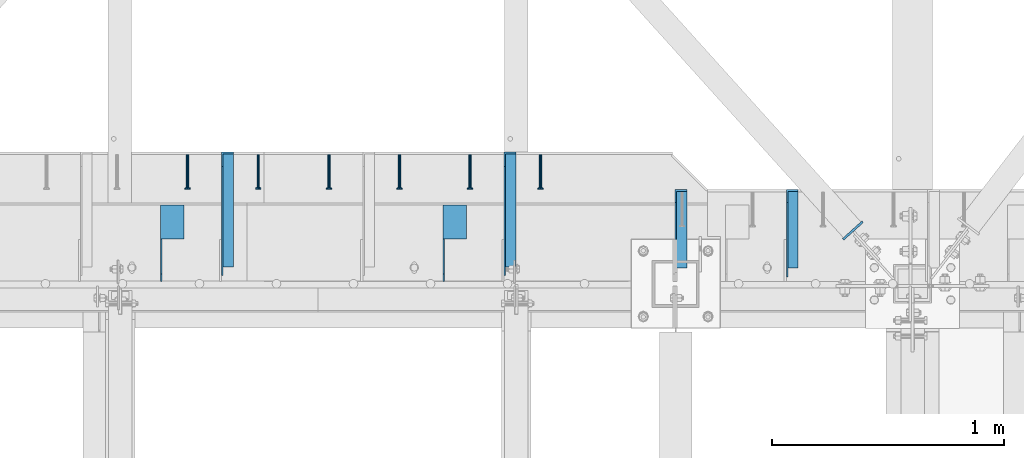
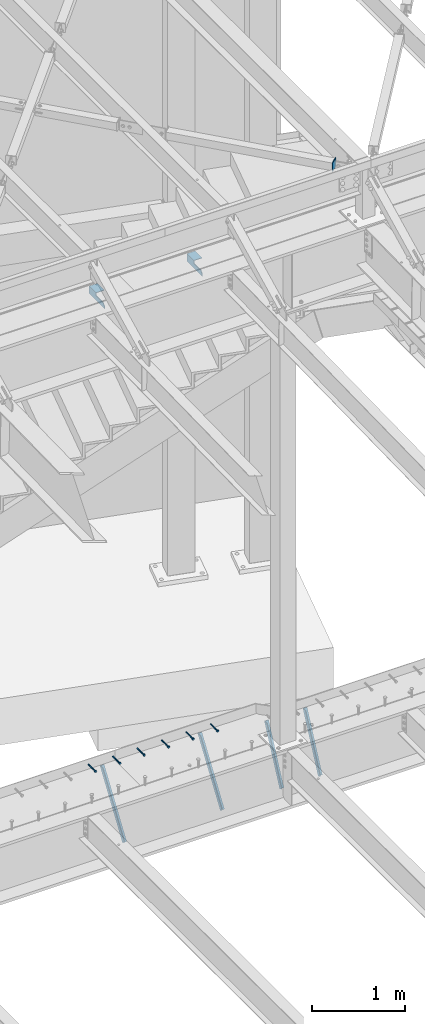
# One storey, part 1374 of 1763: 9 beams, 4 members, 9 elements without a shape of their own.
"""IFC2X3 building model written with IfcOpenShell, lengths in millimetres."""

from ifc_helpers import new_model, si_unit, frame, origin_with_axes, place, context, subcontext, project, spatial, faceted_brep, material, type_object, element, aggregate, save


model = new_model("IFC2X3")

# Units and contexts
model_context = context("Model", 3, precision=1e-05, world=origin_with_axes())
body_context = subcontext(model_context, "Body", "Model", "MODEL_VIEW")
ifc_project = project(units=[si_unit("LENGTHUNIT", "METRE", prefix="MILLI"), si_unit("AREAUNIT", "SQUARE_METRE"), si_unit("VOLUMEUNIT", "CUBIC_METRE"), si_unit("MASSUNIT", "GRAM", prefix="KILO"), si_unit("TIMEUNIT", "SECOND"), si_unit("PLANEANGLEUNIT", "RADIAN"), si_unit("SOLIDANGLEUNIT", "STERADIAN"), si_unit("THERMODYNAMICTEMPERATUREUNIT", "DEGREE_CELSIUS"), si_unit("LUMINOUSINTENSITYUNIT", "LUMEN")], contexts=[model_context])

# Site, building, storey
site_placement = place(None, origin_with_axes())
site = spatial("IfcSite", under=ifc_project, at=site_placement, CompositionType="ELEMENT")
building_placement = place(site_placement, origin_with_axes())
building = spatial("IfcBuilding", under=site, at=building_placement, Name="Undefined", CompositionType="ELEMENT")
storey_placement = place(building_placement, origin_with_axes())
storey = spatial("IfcBuildingStorey", under=building, at=storey_placement, Name="Undefined", CompositionType="ELEMENT", Elevation=0.0)

# Assembly, beam
assembly_1_placement = place(storey_placement, origin_with_axes())
assembly_1 = element("IfcElementAssembly", 1, at=assembly_1_placement, inside=storey, Name="HEADED STUD ANCHOR", AssemblyPlace="NOTDEFINED", PredefinedType="RIGID_FRAME")
ifc_material_1 = material(Name="STEEL/A108")
beam_type_1 = type_object("IfcBeamType", PredefinedType="NOTDEFINED")
beam_1_placement = place(assembly_1_placement, frame((-27582.6466486983, 52679.6000091552, 5264.23140606069), z_axis=(0.0, 0.0, 1.0), x_axis=(0.0, -1.0, 0.0)))
beam_1 = element("IfcBeam", 2, at=beam_1_placement, type_object=beam_type_1, material=ifc_material_1, Name="HEADED STUD ANCHOR", context=body_context, shape_type="Brep", body=[
    faceted_brep([(0.0, -3.1800000667572, 5.5), (0.0, -5.5, 3.1800000667572), (141.732000000002, -5.5, 3.1800000667572), (141.732000000002, -3.1800000667572, 5.5), (0.0, -6.34999999999491, 1.45519152283669e-11), (141.732000000002, -6.34999990463257, 0.0), (0.0, -5.5, -3.1800000667572), (141.732000000002, -5.5, -3.1800000667572), (0.0, -3.1800000667572, -5.5), (141.732000000002, -3.1800000667572, -5.5), (0.0, 0.0, -6.34999990463257), (141.732000000002, 0.0, -6.34999990463257), (0.0, 3.1800000667572, -5.5), (141.732000000002, 3.1800000667572, -5.5), (0.0, 5.5, -3.1800000667572), (141.732000000002, 5.5, -3.1800000667572), (0.0, 6.34999999999491, -2.91038304567337e-11), (141.732000000002, 6.34999990463257, 0.0), (0.0, 5.5, 3.1800000667572), (141.732000000002, 5.5, 3.1800000667572), (0.0, 3.1800000667572, 5.5), (141.732000000002, 3.1800000667572, 5.5), (0.0, 0.0, 6.34999990463257), (141.732000000002, 0.0, 6.34999990463257), (144.780000000001, -10.9899997711182, 6.34999990463257), (144.780000000001, -6.34000015258789, 10.9899997711182), (144.780000000001, -12.6999998092651, 0.0), (144.780000000001, -10.9899997711182, -6.34999990463257), (144.780000000001, -6.34000015258789, -10.9899997711182), (144.780000000001, 0.0, -12.6899995803833), (144.780000000001, 6.34000015258789, -10.9899997711182), (144.780000000001, 10.9899997711182, -6.34999990463257), (144.780000000001, 12.6999998092651, 0.0), (144.780000000001, 10.9899997711182, 6.34999990463257), (144.780000000001, 6.34000015258789, 10.9899997711182), (144.780000000001, 0.0, 12.6899995803833), (152.400000000001, -10.9899997711182, 6.34999990463257), (152.400000000001, -6.34000015258789, 10.9899997711182), (152.400000000001, -12.6999998092651, 0.0), (152.400000000001, -10.9899997711182, -6.34999990463257), (152.400000000001, -6.34000015258789, -10.9899997711182), (152.400000000001, 0.0, -12.6899995803833), (152.400000000001, 6.34000015258789, -10.9899997711182), (152.400000000001, 10.9899997711182, -6.34999990463257), (152.400000000001, 12.6999998092651, 0.0), (152.400000000001, 10.9899997711182, 6.34999990463257), (152.400000000001, 6.34000015258789, 10.9899997711182), (152.400000000001, 0.0, 12.6899995803833)], [[[0, 1, 2, 3]], [[1, 4, 5, 2]], [[4, 6, 7, 5]], [[6, 8, 9, 7]], [[8, 10, 11, 9]], [[10, 12, 13, 11]], [[12, 14, 15, 13]], [[14, 16, 17, 15]], [[16, 18, 19, 17]], [[18, 20, 21, 19]], [[20, 22, 23, 21]], [[22, 0, 3, 23]], [[22, 20, 18, 16, 14, 12, 10, 8, 6, 4, 1, 0]], [[3, 2, 24, 25]], [[2, 5, 26, 24]], [[5, 7, 27, 26]], [[7, 9, 28, 27]], [[9, 11, 29, 28]], [[11, 13, 30, 29]], [[13, 15, 31, 30]], [[15, 17, 32, 31]], [[17, 19, 33, 32]], [[19, 21, 34, 33]], [[21, 23, 35, 34]], [[23, 3, 25, 35]], [[25, 24, 36, 37]], [[24, 26, 38, 36]], [[26, 27, 39, 38]], [[27, 28, 40, 39]], [[28, 29, 41, 40]], [[29, 30, 42, 41]], [[30, 31, 43, 42]], [[31, 32, 44, 43]], [[32, 33, 45, 44]], [[33, 34, 46, 45]], [[34, 35, 47, 46]], [[35, 25, 37, 47]], [[38, 39, 40, 41, 42, 43, 44, 45, 46, 47, 37, 36]]]),
])
aggregate(assembly_1, [beam_1])

assembly_2_placement = place(storey_placement, origin_with_axes())
assembly_2 = element("IfcElementAssembly", 3, at=assembly_2_placement, inside=storey, Name="HEADED STUD ANCHOR", AssemblyPlace="NOTDEFINED", PredefinedType="RIGID_FRAME")
beam_2_placement = place(assembly_2_placement, frame((-27887.4466486983, 52679.6000091552, 5264.23140606069), z_axis=(0.0, 0.0, 1.0), x_axis=(0.0, -1.0, 0.0)))
beam_2 = element("IfcBeam", 4, at=beam_2_placement, type_object=beam_type_1, material=ifc_material_1, Name="HEADED STUD ANCHOR", context=body_context, shape_type="Brep", body=[
    faceted_brep([(0.0, -3.1800000667572, 5.5), (0.0, -5.5, 3.1800000667572), (141.732000000002, -5.5, 3.1800000667572), (141.732000000002, -3.1800000667572, 5.5), (0.0, -6.34999999999491, 1.45519152283669e-11), (141.732000000002, -6.34999990463257, 0.0), (0.0, -5.5, -3.1800000667572), (141.732000000002, -5.5, -3.1800000667572), (0.0, -3.1800000667572, -5.5), (141.732000000002, -3.1800000667572, -5.5), (0.0, 0.0, -6.34999990463257), (141.732000000002, 0.0, -6.34999990463257), (0.0, 3.1800000667572, -5.5), (141.732000000002, 3.1800000667572, -5.5), (0.0, 5.5, -3.1800000667572), (141.732000000002, 5.5, -3.1800000667572), (0.0, 6.34999999999491, -2.91038304567337e-11), (141.732000000002, 6.34999990463257, 0.0), (0.0, 5.5, 3.1800000667572), (141.732000000002, 5.5, 3.1800000667572), (0.0, 3.1800000667572, 5.5), (141.732000000002, 3.1800000667572, 5.5), (0.0, 0.0, 6.34999990463257), (141.732000000002, 0.0, 6.34999990463257), (144.780000000001, -10.9899997711182, 6.34999990463257), (144.780000000001, -6.34000015258789, 10.9899997711182), (144.780000000001, -12.6999998092651, 0.0), (144.780000000001, -10.9899997711182, -6.34999990463257), (144.780000000001, -6.34000015258789, -10.9899997711182), (144.780000000001, 0.0, -12.6899995803833), (144.780000000001, 6.34000015258789, -10.9899997711182), (144.780000000001, 10.9899997711182, -6.34999990463257), (144.780000000001, 12.6999998092651, 0.0), (144.780000000001, 10.9899997711182, 6.34999990463257), (144.780000000001, 6.34000015258789, 10.9899997711182), (144.780000000001, 0.0, 12.6899995803833), (152.400000000001, -10.9899997711182, 6.34999990463257), (152.400000000001, -6.34000015258789, 10.9899997711182), (152.400000000001, -12.6999998092651, 0.0), (152.400000000001, -10.9899997711182, -6.34999990463257), (152.400000000001, -6.34000015258789, -10.9899997711182), (152.400000000001, 0.0, -12.6899995803833), (152.400000000001, 6.34000015258789, -10.9899997711182), (152.400000000001, 10.9899997711182, -6.34999990463257), (152.400000000001, 12.6999998092651, 0.0), (152.400000000001, 10.9899997711182, 6.34999990463257), (152.400000000001, 6.34000015258789, 10.9899997711182), (152.400000000001, 0.0, 12.6899995803833)], [[[0, 1, 2, 3]], [[1, 4, 5, 2]], [[4, 6, 7, 5]], [[6, 8, 9, 7]], [[8, 10, 11, 9]], [[10, 12, 13, 11]], [[12, 14, 15, 13]], [[14, 16, 17, 15]], [[16, 18, 19, 17]], [[18, 20, 21, 19]], [[20, 22, 23, 21]], [[22, 0, 3, 23]], [[22, 20, 18, 16, 14, 12, 10, 8, 6, 4, 1, 0]], [[3, 2, 24, 25]], [[2, 5, 26, 24]], [[5, 7, 27, 26]], [[7, 9, 28, 27]], [[9, 11, 29, 28]], [[11, 13, 30, 29]], [[13, 15, 31, 30]], [[15, 17, 32, 31]], [[17, 19, 33, 32]], [[19, 21, 34, 33]], [[21, 23, 35, 34]], [[23, 3, 25, 35]], [[25, 24, 36, 37]], [[24, 26, 38, 36]], [[26, 27, 39, 38]], [[27, 28, 40, 39]], [[28, 29, 41, 40]], [[29, 30, 42, 41]], [[30, 31, 43, 42]], [[31, 32, 44, 43]], [[32, 33, 45, 44]], [[33, 34, 46, 45]], [[34, 35, 47, 46]], [[35, 25, 37, 47]], [[38, 39, 40, 41, 42, 43, 44, 45, 46, 47, 37, 36]]]),
])
aggregate(assembly_2, [beam_2])

assembly_3_placement = place(storey_placement, origin_with_axes())
assembly_3 = element("IfcElementAssembly", 5, at=assembly_3_placement, inside=storey, Name="HEADED STUD ANCHOR", AssemblyPlace="NOTDEFINED", PredefinedType="RIGID_FRAME")
beam_3_placement = place(assembly_3_placement, frame((-28192.2466486983, 52679.6000091552, 5264.23140606069), z_axis=(0.0, 0.0, 1.0), x_axis=(0.0, -1.0, 0.0)))
beam_3 = element("IfcBeam", 6, at=beam_3_placement, type_object=beam_type_1, material=ifc_material_1, Name="HEADED STUD ANCHOR", context=body_context, shape_type="Brep", body=[
    faceted_brep([(0.0, -3.1800000667572, 5.5), (0.0, -5.5, 3.1800000667572), (141.732000000002, -5.5, 3.1800000667572), (141.732000000002, -3.1800000667572, 5.5), (0.0, -6.34999999999491, 1.45519152283669e-11), (141.732000000002, -6.34999990463257, 0.0), (0.0, -5.5, -3.1800000667572), (141.732000000002, -5.5, -3.1800000667572), (0.0, -3.1800000667572, -5.5), (141.732000000002, -3.1800000667572, -5.5), (0.0, 0.0, -6.34999990463257), (141.732000000002, 0.0, -6.34999990463257), (0.0, 3.1800000667572, -5.5), (141.732000000002, 3.1800000667572, -5.5), (0.0, 5.5, -3.1800000667572), (141.732000000002, 5.5, -3.1800000667572), (0.0, 6.34999999999491, -2.91038304567337e-11), (141.732000000002, 6.34999990463257, 0.0), (0.0, 5.5, 3.1800000667572), (141.732000000002, 5.5, 3.1800000667572), (0.0, 3.1800000667572, 5.5), (141.732000000002, 3.1800000667572, 5.5), (0.0, 0.0, 6.34999990463257), (141.732000000002, 0.0, 6.34999990463257), (144.780000000001, -10.9899997711182, 6.34999990463257), (144.780000000001, -6.34000015258789, 10.9899997711182), (144.780000000001, -12.6999998092651, 0.0), (144.780000000001, -10.9899997711182, -6.34999990463257), (144.780000000001, -6.34000015258789, -10.9899997711182), (144.780000000001, 0.0, -12.6899995803833), (144.780000000001, 6.34000015258789, -10.9899997711182), (144.780000000001, 10.9899997711182, -6.34999990463257), (144.780000000001, 12.6999998092651, 0.0), (144.780000000001, 10.9899997711182, 6.34999990463257), (144.780000000001, 6.34000015258789, 10.9899997711182), (144.780000000001, 0.0, 12.6899995803833), (152.400000000001, -10.9899997711182, 6.34999990463257), (152.400000000001, -6.34000015258789, 10.9899997711182), (152.400000000001, -12.6999998092651, 0.0), (152.400000000001, -10.9899997711182, -6.34999990463257), (152.400000000001, -6.34000015258789, -10.9899997711182), (152.400000000001, 0.0, -12.6899995803833), (152.400000000001, 6.34000015258789, -10.9899997711182), (152.400000000001, 10.9899997711182, -6.34999990463257), (152.400000000001, 12.6999998092651, 0.0), (152.400000000001, 10.9899997711182, 6.34999990463257), (152.400000000001, 6.34000015258789, 10.9899997711182), (152.400000000001, 0.0, 12.6899995803833)], [[[0, 1, 2, 3]], [[1, 4, 5, 2]], [[4, 6, 7, 5]], [[6, 8, 9, 7]], [[8, 10, 11, 9]], [[10, 12, 13, 11]], [[12, 14, 15, 13]], [[14, 16, 17, 15]], [[16, 18, 19, 17]], [[18, 20, 21, 19]], [[20, 22, 23, 21]], [[22, 0, 3, 23]], [[22, 20, 18, 16, 14, 12, 10, 8, 6, 4, 1, 0]], [[3, 2, 24, 25]], [[2, 5, 26, 24]], [[5, 7, 27, 26]], [[7, 9, 28, 27]], [[9, 11, 29, 28]], [[11, 13, 30, 29]], [[13, 15, 31, 30]], [[15, 17, 32, 31]], [[17, 19, 33, 32]], [[19, 21, 34, 33]], [[21, 23, 35, 34]], [[23, 3, 25, 35]], [[25, 24, 36, 37]], [[24, 26, 38, 36]], [[26, 27, 39, 38]], [[27, 28, 40, 39]], [[28, 29, 41, 40]], [[29, 30, 42, 41]], [[30, 31, 43, 42]], [[31, 32, 44, 43]], [[32, 33, 45, 44]], [[33, 34, 46, 45]], [[34, 35, 47, 46]], [[35, 25, 37, 47]], [[38, 39, 40, 41, 42, 43, 44, 45, 46, 47, 37, 36]]]),
])
aggregate(assembly_3, [beam_3])

assembly_4_placement = place(storey_placement, origin_with_axes())
assembly_4 = element("IfcElementAssembly", 7, at=assembly_4_placement, inside=storey, Name="HEADED STUD ANCHOR", AssemblyPlace="NOTDEFINED", PredefinedType="RIGID_FRAME")
beam_4_placement = place(assembly_4_placement, frame((-28497.0466486983, 52679.6000091552, 5264.23140606069), z_axis=(0.0, 0.0, 1.0), x_axis=(0.0, -1.0, 0.0)))
beam_4 = element("IfcBeam", 8, at=beam_4_placement, type_object=beam_type_1, material=ifc_material_1, Name="HEADED STUD ANCHOR", context=body_context, shape_type="Brep", body=[
    faceted_brep([(0.0, -3.1800000667572, 5.5), (0.0, -5.5, 3.1800000667572), (141.732000000002, -5.5, 3.1800000667572), (141.732000000002, -3.1800000667572, 5.5), (0.0, -6.34999999999491, 1.45519152283669e-11), (141.732000000002, -6.34999990463257, 0.0), (0.0, -5.5, -3.1800000667572), (141.732000000002, -5.5, -3.1800000667572), (0.0, -3.1800000667572, -5.5), (141.732000000002, -3.1800000667572, -5.5), (0.0, 0.0, -6.34999990463257), (141.732000000002, 0.0, -6.34999990463257), (0.0, 3.1800000667572, -5.5), (141.732000000002, 3.1800000667572, -5.5), (0.0, 5.5, -3.1800000667572), (141.732000000002, 5.5, -3.1800000667572), (0.0, 6.34999999999491, -2.91038304567337e-11), (141.732000000002, 6.34999990463257, 0.0), (0.0, 5.5, 3.1800000667572), (141.732000000002, 5.5, 3.1800000667572), (0.0, 3.1800000667572, 5.5), (141.732000000002, 3.1800000667572, 5.5), (0.0, 0.0, 6.34999990463257), (141.732000000002, 0.0, 6.34999990463257), (144.780000000001, -10.9899997711182, 6.34999990463257), (144.780000000001, -6.34000015258789, 10.9899997711182), (144.780000000001, -12.6999998092651, 0.0), (144.780000000001, -10.9899997711182, -6.34999990463257), (144.780000000001, -6.34000015258789, -10.9899997711182), (144.780000000001, 0.0, -12.6899995803833), (144.780000000001, 6.34000015258789, -10.9899997711182), (144.780000000001, 10.9899997711182, -6.34999990463257), (144.780000000001, 12.6999998092651, 0.0), (144.780000000001, 10.9899997711182, 6.34999990463257), (144.780000000001, 6.34000015258789, 10.9899997711182), (144.780000000001, 0.0, 12.6899995803833), (152.400000000001, -10.9899997711182, 6.34999990463257), (152.400000000001, -6.34000015258789, 10.9899997711182), (152.400000000001, -12.6999998092651, 0.0), (152.400000000001, -10.9899997711182, -6.34999990463257), (152.400000000001, -6.34000015258789, -10.9899997711182), (152.400000000001, 0.0, -12.6899995803833), (152.400000000001, 6.34000015258789, -10.9899997711182), (152.400000000001, 10.9899997711182, -6.34999990463257), (152.400000000001, 12.6999998092651, 0.0), (152.400000000001, 10.9899997711182, 6.34999990463257), (152.400000000001, 6.34000015258789, 10.9899997711182), (152.400000000001, 0.0, 12.6899995803833)], [[[0, 1, 2, 3]], [[1, 4, 5, 2]], [[4, 6, 7, 5]], [[6, 8, 9, 7]], [[8, 10, 11, 9]], [[10, 12, 13, 11]], [[12, 14, 15, 13]], [[14, 16, 17, 15]], [[16, 18, 19, 17]], [[18, 20, 21, 19]], [[20, 22, 23, 21]], [[22, 0, 3, 23]], [[22, 20, 18, 16, 14, 12, 10, 8, 6, 4, 1, 0]], [[3, 2, 24, 25]], [[2, 5, 26, 24]], [[5, 7, 27, 26]], [[7, 9, 28, 27]], [[9, 11, 29, 28]], [[11, 13, 30, 29]], [[13, 15, 31, 30]], [[15, 17, 32, 31]], [[17, 19, 33, 32]], [[19, 21, 34, 33]], [[21, 23, 35, 34]], [[23, 3, 25, 35]], [[25, 24, 36, 37]], [[24, 26, 38, 36]], [[26, 27, 39, 38]], [[27, 28, 40, 39]], [[28, 29, 41, 40]], [[29, 30, 42, 41]], [[30, 31, 43, 42]], [[31, 32, 44, 43]], [[32, 33, 45, 44]], [[33, 34, 46, 45]], [[34, 35, 47, 46]], [[35, 25, 37, 47]], [[38, 39, 40, 41, 42, 43, 44, 45, 46, 47, 37, 36]]]),
])
aggregate(assembly_4, [beam_4])

assembly_5_placement = place(storey_placement, origin_with_axes())
assembly_5 = element("IfcElementAssembly", 9, at=assembly_5_placement, inside=storey, Name="HEADED STUD ANCHOR", AssemblyPlace="NOTDEFINED", PredefinedType="RIGID_FRAME")
beam_5_placement = place(assembly_5_placement, frame((-28801.8466486983, 52679.6000091552, 5264.23140606069), z_axis=(0.0, 0.0, 1.0), x_axis=(0.0, -1.0, 0.0)))
beam_5 = element("IfcBeam", 10, at=beam_5_placement, type_object=beam_type_1, material=ifc_material_1, Name="HEADED STUD ANCHOR", context=body_context, shape_type="Brep", body=[
    faceted_brep([(0.0, -3.1800000667572, 5.5), (0.0, -5.5, 3.1800000667572), (141.732000000002, -5.5, 3.1800000667572), (141.732000000002, -3.1800000667572, 5.5), (0.0, -6.34999999999491, 1.45519152283669e-11), (141.732000000002, -6.34999990463257, 0.0), (0.0, -5.5, -3.1800000667572), (141.732000000002, -5.5, -3.1800000667572), (0.0, -3.1800000667572, -5.5), (141.732000000002, -3.1800000667572, -5.5), (0.0, 0.0, -6.34999990463257), (141.732000000002, 0.0, -6.34999990463257), (0.0, 3.1800000667572, -5.5), (141.732000000002, 3.1800000667572, -5.5), (0.0, 5.5, -3.1800000667572), (141.732000000002, 5.5, -3.1800000667572), (0.0, 6.34999999999491, -2.91038304567337e-11), (141.732000000002, 6.34999990463257, 0.0), (0.0, 5.5, 3.1800000667572), (141.732000000002, 5.5, 3.1800000667572), (0.0, 3.1800000667572, 5.5), (141.732000000002, 3.1800000667572, 5.5), (0.0, 0.0, 6.34999990463257), (141.732000000002, 0.0, 6.34999990463257), (144.780000000001, -10.9899997711182, 6.34999990463257), (144.780000000001, -6.34000015258789, 10.9899997711182), (144.780000000001, -12.6999998092651, 0.0), (144.780000000001, -10.9899997711182, -6.34999990463257), (144.780000000001, -6.34000015258789, -10.9899997711182), (144.780000000001, 0.0, -12.6899995803833), (144.780000000001, 6.34000015258789, -10.9899997711182), (144.780000000001, 10.9899997711182, -6.34999990463257), (144.780000000001, 12.6999998092651, 0.0), (144.780000000001, 10.9899997711182, 6.34999990463257), (144.780000000001, 6.34000015258789, 10.9899997711182), (144.780000000001, 0.0, 12.6899995803833), (152.400000000001, -10.9899997711182, 6.34999990463257), (152.400000000001, -6.34000015258789, 10.9899997711182), (152.400000000001, -12.6999998092651, 0.0), (152.400000000001, -10.9899997711182, -6.34999990463257), (152.400000000001, -6.34000015258789, -10.9899997711182), (152.400000000001, 0.0, -12.6899995803833), (152.400000000001, 6.34000015258789, -10.9899997711182), (152.400000000001, 10.9899997711182, -6.34999990463257), (152.400000000001, 12.6999998092651, 0.0), (152.400000000001, 10.9899997711182, 6.34999990463257), (152.400000000001, 6.34000015258789, 10.9899997711182), (152.400000000001, 0.0, 12.6899995803833)], [[[0, 1, 2, 3]], [[1, 4, 5, 2]], [[4, 6, 7, 5]], [[6, 8, 9, 7]], [[8, 10, 11, 9]], [[10, 12, 13, 11]], [[12, 14, 15, 13]], [[14, 16, 17, 15]], [[16, 18, 19, 17]], [[18, 20, 21, 19]], [[20, 22, 23, 21]], [[22, 0, 3, 23]], [[22, 20, 18, 16, 14, 12, 10, 8, 6, 4, 1, 0]], [[3, 2, 24, 25]], [[2, 5, 26, 24]], [[5, 7, 27, 26]], [[7, 9, 28, 27]], [[9, 11, 29, 28]], [[11, 13, 30, 29]], [[13, 15, 31, 30]], [[15, 17, 32, 31]], [[17, 19, 33, 32]], [[19, 21, 34, 33]], [[21, 23, 35, 34]], [[23, 3, 25, 35]], [[25, 24, 36, 37]], [[24, 26, 38, 36]], [[26, 27, 39, 38]], [[27, 28, 40, 39]], [[28, 29, 41, 40]], [[29, 30, 42, 41]], [[30, 31, 43, 42]], [[31, 32, 44, 43]], [[32, 33, 45, 44]], [[33, 34, 46, 45]], [[34, 35, 47, 46]], [[35, 25, 37, 47]], [[38, 39, 40, 41, 42, 43, 44, 45, 46, 47, 37, 36]]]),
])
aggregate(assembly_5, [beam_5])

assembly_6_placement = place(storey_placement, origin_with_axes())
assembly_6 = element("IfcElementAssembly", 11, at=assembly_6_placement, inside=storey, Name="HEADED STUD ANCHOR", AssemblyPlace="NOTDEFINED", PredefinedType="RIGID_FRAME")
beam_6_placement = place(assembly_6_placement, frame((-29106.6466486983, 52679.6000091552, 5264.23140606069), z_axis=(0.0, 0.0, 1.0), x_axis=(0.0, -1.0, 0.0)))
beam_6 = element("IfcBeam", 12, at=beam_6_placement, type_object=beam_type_1, material=ifc_material_1, Name="HEADED STUD ANCHOR", context=body_context, shape_type="Brep", body=[
    faceted_brep([(0.0, -3.1800000667572, 5.5), (0.0, -5.5, 3.1800000667572), (141.732000000002, -5.5, 3.1800000667572), (141.732000000002, -3.1800000667572, 5.5), (0.0, -6.34999999999491, 1.45519152283669e-11), (141.732000000002, -6.34999990463257, 0.0), (0.0, -5.5, -3.1800000667572), (141.732000000002, -5.5, -3.1800000667572), (0.0, -3.1800000667572, -5.5), (141.732000000002, -3.1800000667572, -5.5), (0.0, 0.0, -6.34999990463257), (141.732000000002, 0.0, -6.34999990463257), (0.0, 3.1800000667572, -5.5), (141.732000000002, 3.1800000667572, -5.5), (0.0, 5.5, -3.1800000667572), (141.732000000002, 5.5, -3.1800000667572), (0.0, 6.34999999999491, -2.91038304567337e-11), (141.732000000002, 6.34999990463257, 0.0), (0.0, 5.5, 3.1800000667572), (141.732000000002, 5.5, 3.1800000667572), (0.0, 3.1800000667572, 5.5), (141.732000000002, 3.1800000667572, 5.5), (0.0, 0.0, 6.34999990463257), (141.732000000002, 0.0, 6.34999990463257), (144.780000000001, -10.9899997711182, 6.34999990463257), (144.780000000001, -6.34000015258789, 10.9899997711182), (144.780000000001, -12.6999998092651, 0.0), (144.780000000001, -10.9899997711182, -6.34999990463257), (144.780000000001, -6.34000015258789, -10.9899997711182), (144.780000000001, 0.0, -12.6899995803833), (144.780000000001, 6.34000015258789, -10.9899997711182), (144.780000000001, 10.9899997711182, -6.34999990463257), (144.780000000001, 12.6999998092651, 0.0), (144.780000000001, 10.9899997711182, 6.34999990463257), (144.780000000001, 6.34000015258789, 10.9899997711182), (144.780000000001, 0.0, 12.6899995803833), (152.400000000001, -10.9899997711182, 6.34999990463257), (152.400000000001, -6.34000015258789, 10.9899997711182), (152.400000000001, -12.6999998092651, 0.0), (152.400000000001, -10.9899997711182, -6.34999990463257), (152.400000000001, -6.34000015258789, -10.9899997711182), (152.400000000001, 0.0, -12.6899995803833), (152.400000000001, 6.34000015258789, -10.9899997711182), (152.400000000001, 10.9899997711182, -6.34999990463257), (152.400000000001, 12.6999998092651, 0.0), (152.400000000001, 10.9899997711182, 6.34999990463257), (152.400000000001, 6.34000015258789, 10.9899997711182), (152.400000000001, 0.0, 12.6899995803833)], [[[0, 1, 2, 3]], [[1, 4, 5, 2]], [[4, 6, 7, 5]], [[6, 8, 9, 7]], [[8, 10, 11, 9]], [[10, 12, 13, 11]], [[12, 14, 15, 13]], [[14, 16, 17, 15]], [[16, 18, 19, 17]], [[18, 20, 21, 19]], [[20, 22, 23, 21]], [[22, 0, 3, 23]], [[22, 20, 18, 16, 14, 12, 10, 8, 6, 4, 1, 0]], [[3, 2, 24, 25]], [[2, 5, 26, 24]], [[5, 7, 27, 26]], [[7, 9, 28, 27]], [[9, 11, 29, 28]], [[11, 13, 30, 29]], [[13, 15, 31, 30]], [[15, 17, 32, 31]], [[17, 19, 33, 32]], [[19, 21, 34, 33]], [[21, 23, 35, 34]], [[23, 3, 25, 35]], [[25, 24, 36, 37]], [[24, 26, 38, 36]], [[26, 27, 39, 38]], [[27, 28, 40, 39]], [[28, 29, 41, 40]], [[29, 30, 42, 41]], [[30, 31, 43, 42]], [[31, 32, 44, 43]], [[32, 33, 45, 44]], [[33, 34, 46, 45]], [[34, 35, 47, 46]], [[35, 25, 37, 47]], [[38, 39, 40, 41, 42, 43, 44, 45, 46, 47, 37, 36]]]),
])
aggregate(assembly_6, [beam_6])

# Assembly, members
assembly_7_placement = place(storey_placement, origin_with_axes())
assembly_7 = element("IfcElementAssembly", 13, at=assembly_7_placement, inside=storey, Name="BEAM", AssemblyPlace="NOTDEFINED", PredefinedType="RIGID_FRAME")
ifc_material_2 = material(Name="STEEL/A36")
member_type = type_object("IfcMemberType", Name="L2X2X1/4", PredefinedType="NOTDEFINED")
member_1_placement = place(assembly_7_placement, frame((-26496.2370109278, 52172.6912661611, 4509.47070366736), z_axis=(0.0, -0.902782435029662, 0.430097518014128), x_axis=(0.0, 0.43009751801413, 0.902782435029662)))
member_1 = element("IfcMember", 14, at=member_1_placement, type_object=member_type, material=ifc_material_2, Name="ANGLE", ObjectType="L2X2X1/4", context=body_context, shape_type="Brep", body=[
    faceted_brep([(-1.45519152283669e-11, 25.4000000000015, -25.3999999999869), (1.45519152283669e-11, 25.4000000000015, 25.3999999999796), (746.475333672606, 25.4000000000015, 25.3999999987791), (770.677127003386, 25.4000000000015, -25.400000001122), (1.45519152283669e-11, 19.0499999999993, 25.3999999999796), (746.475333672606, 19.0499999999993, 25.3999999987791), (-7.27595761418343e-12, 19.0499999999993, -19.0499999999956), (767.651902837039, 19.0499999999993, -19.050000001138), (-7.27595761418343e-12, -25.4000000000015, -19.0499999999956), (767.651902837039, -25.4000000000015, -19.050000001138), (-1.45519152283669e-11, -25.4000000000015, -25.3999999999869), (770.677127003386, -25.4000000000015, -25.400000001122)], [[[0, 1, 2, 3]], [[1, 4, 5, 2]], [[4, 6, 7, 5]], [[6, 8, 9, 7]], [[8, 10, 11, 9]], [[10, 0, 3, 11]], [[5, 7, 9, 11, 3, 2]], [[10, 8, 6, 4, 1, 0]]]),
])
member_2_placement = place(assembly_7_placement, frame((-26976.6185236984, 52172.6912662575, 4509.47070362112), z_axis=(0.0, -0.902782435029662, 0.430097518014128), x_axis=(0.0, 0.43009751801413, 0.902782435029662)))
member_2 = element("IfcMember", 15, at=member_2_placement, type_object=member_type, material=ifc_material_2, Name="ANGLE", ObjectType="L2X2X1/4", context=body_context, shape_type="Brep", body=[
    faceted_brep([(-1.45519152283669e-11, 25.4000000000015, -25.3999999999869), (1.45519152283669e-11, 25.4000000000015, 25.3999999999796), (746.475333672606, 25.4000000000015, 25.3999999987791), (770.677127003386, 25.4000000000015, -25.400000001122), (1.45519152283669e-11, 19.0499999999993, 25.3999999999796), (746.475333672606, 19.0499999999993, 25.3999999987791), (-7.27595761418343e-12, 19.0499999999993, -19.0499999999956), (767.651902837039, 19.0499999999993, -19.050000001138), (-7.27595761418343e-12, -25.4000000000015, -19.0499999999956), (767.651902837039, -25.4000000000015, -19.050000001138), (-1.45519152283669e-11, -25.4000000000015, -25.3999999999869), (770.677127003386, -25.4000000000015, -25.400000001122)], [[[0, 1, 2, 3]], [[1, 4, 5, 2]], [[4, 6, 7, 5]], [[6, 8, 9, 7]], [[8, 10, 11, 9]], [[10, 0, 3, 11]], [[5, 7, 9, 11, 3, 2]], [[10, 8, 6, 4, 1, 0]]]),
])
member_3_placement = place(assembly_7_placement, frame((-27715.4370109278, 52177.7789126344, 4484.66874800095), z_axis=(0.0, -0.827940419190063, 0.560816068128742), x_axis=(0.0, 0.560816068128741, 0.827940419190064)))
member_3 = element("IfcMember", 16, at=member_3_placement, type_object=member_type, material=ifc_material_2, Name="ANGLE", ObjectType="L2X2X1/4", context=body_context, shape_type="Brep", body=[
    faceted_brep([(-1.45519152283669e-11, 25.4000000000015, -25.3999999999869), (1.45519152283669e-11, 25.4000000000015, 25.3999999999796), (839.899233991324, 25.4000000000015, 25.3999999994412), (874.309265921926, 25.4000000000015, -25.4000000006854), (1.45519152283669e-11, 19.0499999999993, 25.3999999999796), (839.899233991324, 19.0499999999993, 25.3999999994412), (-7.27595761418343e-12, 19.0499999999993, -19.0499999999956), (870.0080119306, 19.0499999999993, -19.0500000006723), (-7.27595761418343e-12, -25.4000000000015, -19.0499999999956), (870.0080119306, -25.4000000000015, -19.0500000006723), (-1.45519152283669e-11, -25.4000000000015, -25.3999999999869), (874.309265921926, -25.4000000000015, -25.4000000006854)], [[[0, 1, 2, 3]], [[1, 4, 5, 2]], [[4, 6, 7, 5]], [[6, 8, 9, 7]], [[8, 10, 11, 9]], [[10, 0, 3, 11]], [[5, 7, 9, 11, 3, 2]], [[10, 8, 6, 4, 1, 0]]]),
])
member_4_placement = place(assembly_7_placement, frame((-28934.6370109278, 52177.7789126344, 4484.66874800095), z_axis=(0.0, -0.827940419190063, 0.560816068128742), x_axis=(0.0, 0.560816068128741, 0.827940419190064)))
member_4 = element("IfcMember", 17, at=member_4_placement, type_object=member_type, material=ifc_material_2, Name="ANGLE", ObjectType="L2X2X1/4", context=body_context, shape_type="Brep", body=[
    faceted_brep([(-1.45519152283669e-11, 25.4000000000015, -25.3999999999869), (1.45519152283669e-11, 25.4000000000015, 25.3999999999796), (839.899233991324, 25.4000000000015, 25.3999999994412), (874.309265921926, 25.4000000000015, -25.4000000006854), (1.45519152283669e-11, 19.0499999999993, 25.3999999999796), (839.899233991324, 19.0499999999993, 25.3999999994412), (-7.27595761418343e-12, 19.0499999999993, -19.0499999999956), (870.0080119306, 19.0499999999993, -19.0500000006723), (-7.27595761418343e-12, -25.4000000000015, -19.0499999999956), (870.0080119306, -25.4000000000015, -19.0500000006723), (-1.45519152283669e-11, -25.4000000000015, -25.3999999999869), (874.309265921926, -25.4000000000015, -25.4000000006854)], [[[0, 1, 2, 3]], [[1, 4, 5, 2]], [[4, 6, 7, 5]], [[6, 8, 9, 7]], [[8, 10, 11, 9]], [[10, 0, 3, 11]], [[5, 7, 9, 11, 3, 2]], [[10, 8, 6, 4, 1, 0]]]),
])
aggregate(assembly_7, [member_1, member_2, member_3, member_4])

# Assembly, beams
assembly_8_placement = place(storey_placement, origin_with_axes())
assembly_8 = element("IfcElementAssembly", 18, at=assembly_8_placement, inside=storey, Name="BEAM", AssemblyPlace="NOTDEFINED", PredefinedType="RIGID_FRAME")
beam_type_2 = type_object("IfcBeamType", Name="L4X4X1/4", PredefinedType="NOTDEFINED")
beam_7_placement = place(assembly_8_placement, frame((-27953.7247736984, 52462.1124819023, 11696.6999917654), z_axis=(0.0, 0.0, -1.0), x_axis=(0.0, -1.0, 0.0)))
beam_7 = element("IfcBeam", 19, at=beam_7_placement, type_object=beam_type_2, material=ifc_material_2, Name="BRACE", ObjectType="L4X4X1/4", context=body_context, shape_type="Brep", body=[
    faceted_brep([(148.43173432786, 44.4500000000007, -44.4500000000007), (148.431790430077, -50.7999999999993, -44.4500000000007), (148.431790785675, -50.7999999999993, -50.7999999999993), (148.43173094331, 50.7999999999993, -50.7999999999993), (148.431728809323, 50.7999999999993, -12.6999970794623), (148.431732549492, 44.4500000000007, -12.6999970794623), (299.243731689443, 50.7999999999993, -12.7000043904281), (299.243731689443, 44.4499999999971, -12.7000043904281), (2.11002770811319e-10, -50.8000000000357, -50.799999999952), (1.96450855582952e-10, -50.8000000000338, -44.4499999999534), (-2.18278728425503e-11, 44.4500000000007, -44.450000000048), (-1.81898940354586e-10, 44.4500000000371, 50.7999999999374), (-1.96450855582952e-10, 50.8000000000393, 50.7999999999374), (-3.63797880709171e-11, 50.8000000000011, -50.8000000000538), (330.993731689443, 44.4500000000007, 50.7999999999993), (330.993731689443, 50.7999999999993, 50.7999999999993), (330.993731689443, 44.4500000000007, 19.050000000012), (330.993731689443, 50.7999999999993, 19.050000000012)], [[[0, 1, 2, 3, 4, 5]], [[5, 4, 6, 7]], [[8, 9, 10, 11, 12, 13]], [[12, 11, 14, 15]], [[15, 14, 16, 17]], [[16, 7, 6, 17]], [[4, 3, 13, 12, 15, 17, 6]], [[8, 13, 3, 2]], [[9, 8, 2, 1]], [[10, 9, 1, 0]], [[14, 11, 10, 0, 5, 7, 16]]]),
])
beam_8_placement = place(assembly_8_placement, frame((-29172.9247736984, 52462.1124819023, 11696.6999917654), z_axis=(0.0, 0.0, -1.0), x_axis=(0.0, -1.0, 0.0)))
beam_8 = element("IfcBeam", 20, at=beam_8_placement, type_object=beam_type_2, material=ifc_material_2, Name="BRACE", ObjectType="L4X4X1/4", context=body_context, shape_type="Brep", body=[
    faceted_brep([(148.43173432786, 44.4500000000007, -44.4500000000007), (148.431790430077, -50.7999999999993, -44.4500000000007), (148.431790785675, -50.7999999999993, -50.7999999999993), (148.43173094331, 50.7999999999993, -50.7999999999993), (148.431728809323, 50.7999999999993, -12.6999970794623), (148.431732549492, 44.4500000000007, -12.6999970794623), (299.243731689443, 50.7999999999993, -12.7000043904281), (299.243731689443, 44.4499999999971, -12.7000043904281), (2.11002770811319e-10, -50.8000000000357, -50.799999999952), (1.96450855582952e-10, -50.8000000000338, -44.4499999999534), (-2.18278728425503e-11, 44.4500000000007, -44.450000000048), (-1.81898940354586e-10, 44.4500000000371, 50.7999999999374), (-1.96450855582952e-10, 50.8000000000393, 50.7999999999374), (-3.63797880709171e-11, 50.8000000000011, -50.8000000000538), (330.993731689443, 44.4500000000007, 50.7999999999993), (330.993731689443, 50.7999999999993, 50.7999999999993), (330.993731689443, 44.4500000000007, 19.050000000012), (330.993731689443, 50.7999999999993, 19.050000000012)], [[[0, 1, 2, 3, 4, 5]], [[5, 4, 6, 7]], [[8, 9, 10, 11, 12, 13]], [[12, 11, 14, 15]], [[15, 14, 16, 17]], [[16, 7, 6, 17]], [[4, 3, 13, 12, 15, 17, 6]], [[8, 13, 3, 2]], [[9, 8, 2, 1]], [[10, 9, 1, 0]], [[14, 11, 10, 0, 5, 7, 16]]]),
])
aggregate(assembly_8, [beam_7, beam_8])

# Assembly, beam
assembly_9_placement = place(storey_placement, origin_with_axes())
assembly_9 = element("IfcElementAssembly", 21, at=assembly_9_placement, inside=storey, Name="H. BRACE", AssemblyPlace="NOTDEFINED", PredefinedType="RIGID_FRAME")
beam_type_3 = type_object("IfcBeamType", PredefinedType="NOTDEFINED")
beam_9_placement = place(assembly_9_placement, frame((-26234.5603905981, 52350.6191485021, 12428.5375), z_axis=(0.742790044081369, 0.669524421073345, 0.0), x_axis=(0.0, 0.0, -1.0)))
beam_9 = element("IfcBeam", 22, at=beam_9_placement, type_object=beam_type_3, material=ifc_material_2, Name="PLATE", context=body_context, shape_type="Brep", body=[
    faceted_brep([(0.0, 4.76249999989523, -57.1500000001702), (0.0, 4.76250000014261, 57.1500000001565), (114.299999999999, 4.76250000014261, 57.1500000001565), (114.299999999999, 4.76249999989523, -57.1500000001702), (0.0, -4.76249999988067, 57.1500000001784), (114.299999999999, -4.76249999988067, 57.1500000001784), (0.0, -4.76250000012806, -57.150000000152), (114.299999999999, -4.76250000012806, -57.150000000152)], [[[0, 1, 2, 3]], [[1, 4, 5, 2]], [[4, 6, 7, 5]], [[6, 0, 3, 7]], [[5, 7, 3, 2]], [[6, 4, 1, 0]]]),
])
aggregate(assembly_9, [beam_9])

save(model, "model.ifc")
